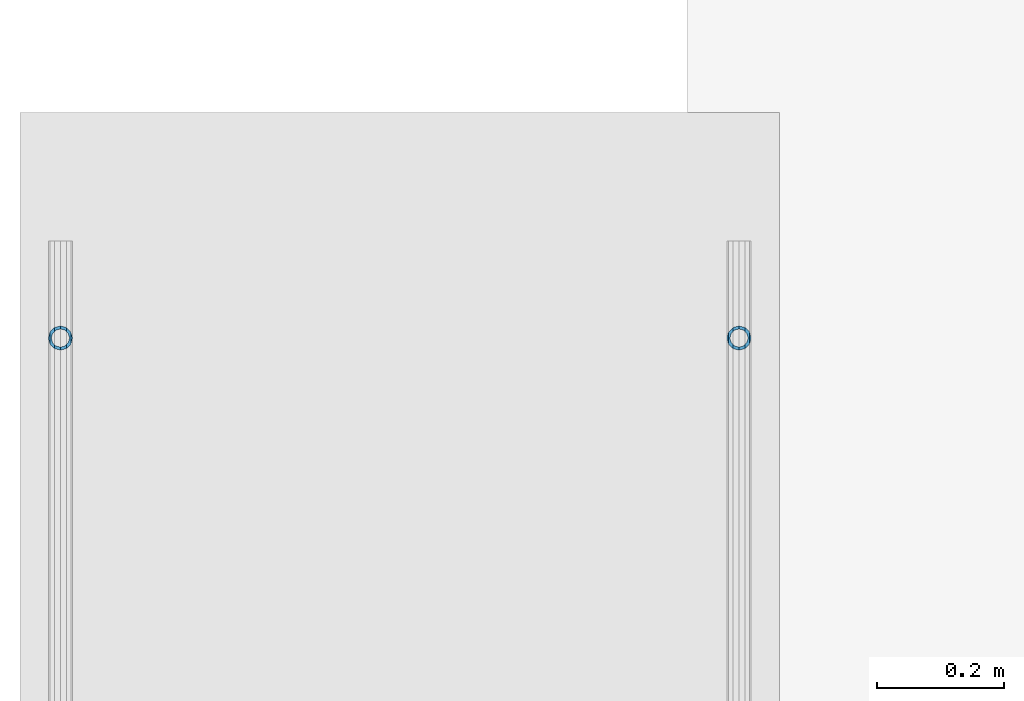
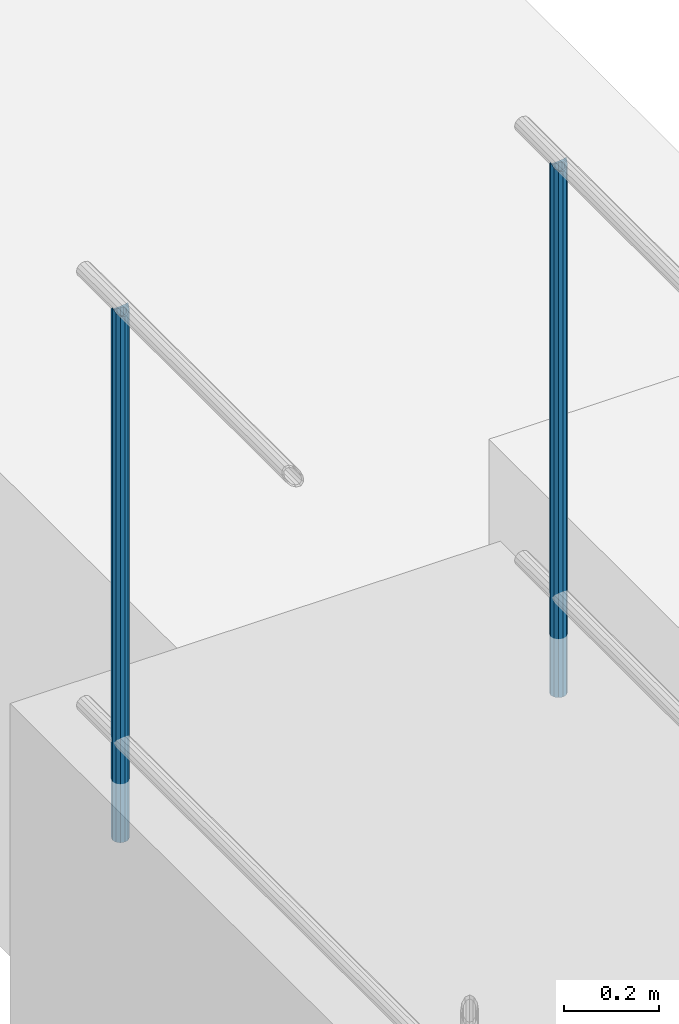
# One storey, part 886 of 1763: 2 columns, 2 elements without a shape of their own.
"""IFC2X3 building model written with IfcOpenShell, lengths in millimetres."""

from ifc_helpers import new_model, si_unit, frame, origin_with_axes, place, context, subcontext, project, spatial, faceted_brep, material, type_object, element, aggregate, save


model = new_model("IFC2X3")

# Units and contexts
model_context = context("Model", 3, precision=1e-05, world=origin_with_axes())
body_context = subcontext(model_context, "Body", "Model", "MODEL_VIEW")
ifc_project = project(units=[si_unit("LENGTHUNIT", "METRE", prefix="MILLI"), si_unit("AREAUNIT", "SQUARE_METRE"), si_unit("VOLUMEUNIT", "CUBIC_METRE"), si_unit("MASSUNIT", "GRAM", prefix="KILO"), si_unit("TIMEUNIT", "SECOND"), si_unit("PLANEANGLEUNIT", "RADIAN"), si_unit("SOLIDANGLEUNIT", "STERADIAN"), si_unit("THERMODYNAMICTEMPERATUREUNIT", "DEGREE_CELSIUS"), si_unit("LUMINOUSINTENSITYUNIT", "LUMEN")], contexts=[model_context])

# Site, building, storey
site_placement = place(None, origin_with_axes())
site = spatial("IfcSite", under=ifc_project, at=site_placement, CompositionType="ELEMENT")
building_placement = place(site_placement, origin_with_axes())
building = spatial("IfcBuilding", under=site, at=building_placement, Name="Undefined", CompositionType="ELEMENT")
storey_placement = place(building_placement, origin_with_axes())
storey = spatial("IfcBuildingStorey", under=building, at=storey_placement, Name="Undefined", CompositionType="ELEMENT", Elevation=0.0)

# Assembly, column
assembly_1_placement = place(storey_placement, origin_with_axes())
assembly_1 = element("IfcElementAssembly", 1, at=assembly_1_placement, inside=storey, Name="GUARDRAIL", AssemblyPlace="NOTDEFINED", PredefinedType="RIGID_FRAME")
ifc_material = material(Name="STEEL/A513")
column_type = type_object("IfcColumnType", PredefinedType="NOTDEFINED")
column_1_placement = place(assembly_1_placement, frame((-97200.6527017878, 12261.6431732146, 5777.83146284698), z_axis=(0.0, -1.0, 0.0), x_axis=(0.0, 0.0, 1.0)))
column_1 = element("IfcColumn", 2, at=column_1_placement, type_object=column_type, material=ifc_material, Name="POST TUBE", context=body_context, shape_type="Brep", body=[
    faceted_brep([(1355.1023212822, -9.52499999999418, 16.4977839408621), (1355.10232491889, -9.52499999999418, 9.99208795533559), (1354.46426957319, -7.14375000000291, 12.3733379553378), (1352.55010645984, 0.0, 14.2874999987689), (1352.5501037976, 0.0, 19.0499999987715), (1354.46426957319, 7.14375000000291, 12.3733379553378), (1355.10232491889, 9.52499999999418, 9.99208795533559), (1355.1023212822, 9.52499999999418, 16.4977839408621), (1371.60011444657, 19.0500000000029, -1.249645720236e-09), (1362.07510912209, 16.4977839420899, 9.52499999875909), (1362.07511977106, 16.4977839420899, -9.52500000124019), (1357.95066446758, 12.3733379565674, 7.14374999876418), (1359.86483050437, 14.2875000000058, -1.23873178381473e-09), (1357.95067245429, 12.3733379565674, -7.14375000123619), (1355.10233609006, 9.52499999999418, -9.99208795780396), (1355.10233972675, 9.52499999999418, -16.4977839433286), (1354.46428340659, 7.14375000000291, -12.3733379578043), (1352.55012243329, 0.0, -14.2875000012336), (1352.55012509553, 0.0, -19.0500000012344), (1355.10233609006, -9.52499999999418, -9.99208795780396), (1355.10233972675, -9.52499999999418, -16.4977839433286), (1354.46428340659, -7.14375000000291, -12.3733379578043), (1371.60011444657, -19.0500000000029, -1.249645720236e-09), (1362.07511977106, -16.4977839420899, -9.52500000124019), (1362.07510912209, -16.4977839420899, 9.52499999875909), (1357.95067245429, -12.3733379565674, -7.14375000123619), (1359.86483050437, -14.2875000000058, -1.23873178381473e-09), (1357.95066446758, -12.3733379565674, 7.14374999876418), (0.0, -16.4977839420899, -9.52500000000146), (0.0, -9.52499999999418, -16.4977839420935), (1.45519152283669e-11, 1.81898940354586e-12, -19.0499999999993), (0.0, 9.52499999999418, -16.4977839420935), (0.0, 16.4977839420899, -9.52500000000146), (0.0, 19.0500000000029, 0.0), (0.0, 16.4977839420899, 9.52500000000146), (0.0, 9.52499999999418, 16.4977839420935), (1.45519152283669e-11, 1.81898940354586e-12, 19.0499999999993), (0.0, -9.52499999999418, 16.4977839420935), (0.0, -16.4977839420899, 9.52500000000146), (0.0, -19.0500000000029, 0.0), (0.0, -12.3733379565674, -7.14374999999927), (0.0, -7.14375000000291, -12.373337956571), (0.0, 0.0, -14.2874999999985), (0.0, 7.14375000000291, -12.373337956571), (0.0, 12.3733379565674, -7.14374999999927), (0.0, 14.2875000000058, 0.0), (0.0, 12.3733379565674, 7.14374999999927), (0.0, 7.14375000000291, 12.373337956571), (0.0, 0.0, 14.2874999999985), (0.0, -7.14375000000291, 12.373337956571), (0.0, -12.3733379565674, 7.14374999999927), (0.0, -14.2875000000058, 0.0)], [[[0, 1, 2, 3, 4]], [[4, 3, 5, 6, 7]], [[8, 9, 10]], [[7, 6, 11, 12, 13, 14, 15, 10, 9]], [[16, 17, 18, 15, 14]], [[19, 20, 18, 17, 21]], [[22, 23, 24]], [[24, 23, 20, 19, 25, 26, 27, 1, 0]], [[28, 29, 20, 23]], [[29, 30, 18, 20]], [[30, 31, 15, 18]], [[31, 32, 10, 15]], [[32, 33, 8, 10]], [[33, 34, 9, 8]], [[34, 35, 7, 9]], [[35, 36, 4, 7]], [[36, 37, 0, 4]], [[37, 38, 24, 0]], [[38, 39, 22, 24]], [[39, 28, 23, 22]], [[38, 37, 36, 35, 34, 33, 32, 31, 30, 29, 28, 39], [40, 41, 42, 43, 44, 45, 46, 47, 48, 49, 50, 51]], [[40, 51, 26, 25]], [[21, 41, 40, 25, 19]], [[42, 41, 21, 17]], [[43, 42, 17, 16]], [[44, 43, 16, 14, 13]], [[45, 44, 13, 12]], [[46, 45, 12, 11]], [[5, 47, 46, 11, 6]], [[48, 47, 5, 3]], [[49, 48, 3, 2]], [[50, 49, 2, 1, 27]], [[51, 50, 27, 26]]]),
])
aggregate(assembly_1, [column_1])

assembly_2_placement = place(storey_placement, origin_with_axes())
assembly_2 = element("IfcElementAssembly", 3, at=assembly_2_placement, inside=storey, Name="GUARDRAIL", AssemblyPlace="NOTDEFINED", PredefinedType="RIGID_FRAME")
column_2_placement = place(assembly_2_placement, frame((-96133.8527017878, 12261.6431732146, 5777.83146284698), z_axis=(0.0, -1.0, 0.0), x_axis=(0.0, 0.0, 1.0)))
column_2 = element("IfcColumn", 4, at=column_2_placement, type_object=column_type, material=ifc_material, Name="POST TUBE", context=body_context, shape_type="Brep", body=[
    faceted_brep([(1355.1023212822, -9.52499999999418, 16.4977839408621), (1355.10232491889, -9.52499999999418, 9.99208795533559), (1354.46426957319, -7.14375000000291, 12.3733379553378), (1352.55010645984, 0.0, 14.2874999987689), (1352.5501037976, 0.0, 19.0499999987715), (1354.46426957319, 7.14375000000291, 12.3733379553378), (1355.10232491889, 9.52499999999418, 9.99208795533559), (1355.1023212822, 9.52499999999418, 16.4977839408621), (1371.60011444657, 19.0500000000029, -1.249645720236e-09), (1362.07510912209, 16.4977839420899, 9.52499999875909), (1362.07511977106, 16.4977839420899, -9.52500000124019), (1357.95066446758, 12.3733379565674, 7.14374999876418), (1359.86483050437, 14.2875000000058, -1.23873178381473e-09), (1357.95067245429, 12.3733379565674, -7.14375000123619), (1355.10233609006, 9.52499999999418, -9.99208795780396), (1355.10233972675, 9.52499999999418, -16.4977839433286), (1354.46428340659, 7.14375000000291, -12.3733379578043), (1352.55012243329, 0.0, -14.2875000012336), (1352.55012509553, 0.0, -19.0500000012344), (1355.10233609006, -9.52499999999418, -9.99208795780396), (1355.10233972675, -9.52499999999418, -16.4977839433286), (1354.46428340659, -7.14375000000291, -12.3733379578043), (1371.60011444657, -19.0500000000029, -1.249645720236e-09), (1362.07511977106, -16.4977839420899, -9.52500000124019), (1362.07510912209, -16.4977839420899, 9.52499999875909), (1357.95067245429, -12.3733379565674, -7.14375000123619), (1359.86483050437, -14.2875000000058, -1.23873178381473e-09), (1357.95066446758, -12.3733379565674, 7.14374999876418), (0.0, -16.4977839420899, -9.52500000000146), (0.0, -9.52499999999418, -16.4977839420935), (1.45519152283669e-11, 1.81898940354586e-12, -19.0499999999993), (0.0, 9.52499999999418, -16.4977839420935), (0.0, 16.4977839420899, -9.52500000000146), (0.0, 19.0500000000029, 0.0), (0.0, 16.4977839420899, 9.52500000000146), (0.0, 9.52499999999418, 16.4977839420935), (1.45519152283669e-11, 1.81898940354586e-12, 19.0499999999993), (0.0, -9.52499999999418, 16.4977839420935), (0.0, -16.4977839420899, 9.52500000000146), (0.0, -19.0500000000029, 0.0), (0.0, -12.3733379565674, -7.14374999999927), (0.0, -7.14375000000291, -12.373337956571), (0.0, 0.0, -14.2874999999985), (0.0, 7.14375000000291, -12.373337956571), (0.0, 12.3733379565674, -7.14374999999927), (0.0, 14.2875000000058, 0.0), (0.0, 12.3733379565674, 7.14374999999927), (0.0, 7.14375000000291, 12.373337956571), (0.0, 0.0, 14.2874999999985), (0.0, -7.14375000000291, 12.373337956571), (0.0, -12.3733379565674, 7.14374999999927), (0.0, -14.2875000000058, 0.0)], [[[0, 1, 2, 3, 4]], [[4, 3, 5, 6, 7]], [[8, 9, 10]], [[7, 6, 11, 12, 13, 14, 15, 10, 9]], [[16, 17, 18, 15, 14]], [[19, 20, 18, 17, 21]], [[22, 23, 24]], [[24, 23, 20, 19, 25, 26, 27, 1, 0]], [[28, 29, 20, 23]], [[29, 30, 18, 20]], [[30, 31, 15, 18]], [[31, 32, 10, 15]], [[32, 33, 8, 10]], [[33, 34, 9, 8]], [[34, 35, 7, 9]], [[35, 36, 4, 7]], [[36, 37, 0, 4]], [[37, 38, 24, 0]], [[38, 39, 22, 24]], [[39, 28, 23, 22]], [[38, 37, 36, 35, 34, 33, 32, 31, 30, 29, 28, 39], [40, 41, 42, 43, 44, 45, 46, 47, 48, 49, 50, 51]], [[40, 51, 26, 25]], [[21, 41, 40, 25, 19]], [[42, 41, 21, 17]], [[43, 42, 17, 16]], [[44, 43, 16, 14, 13]], [[45, 44, 13, 12]], [[46, 45, 12, 11]], [[5, 47, 46, 11, 6]], [[48, 47, 5, 3]], [[49, 48, 3, 2]], [[50, 49, 2, 1, 27]], [[51, 50, 27, 26]]]),
])
aggregate(assembly_2, [column_2])

save(model, "model.ifc")
